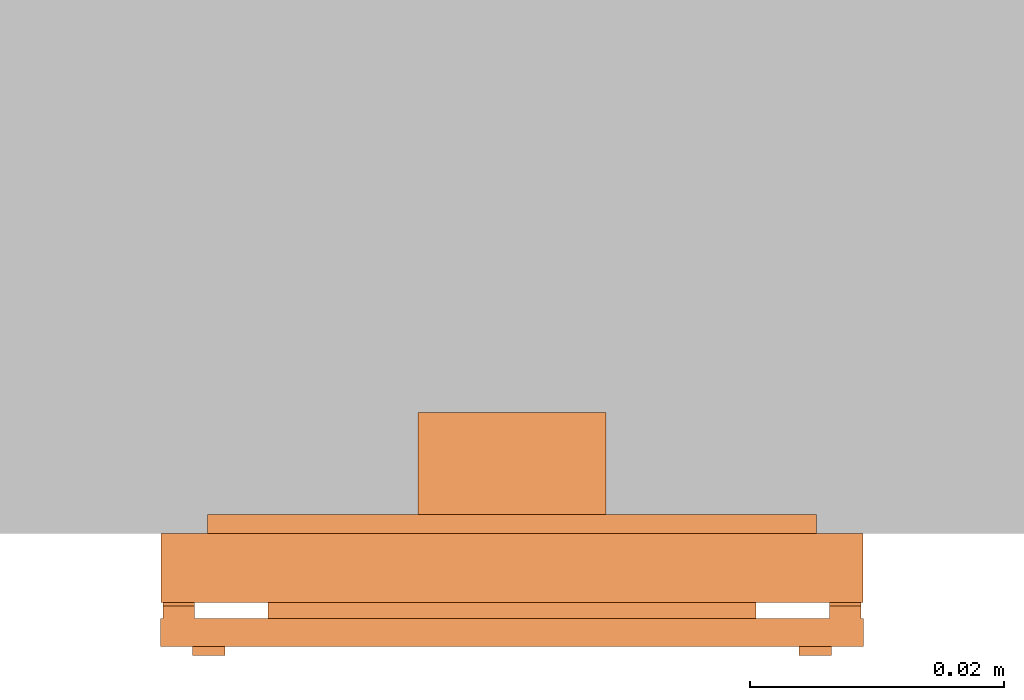
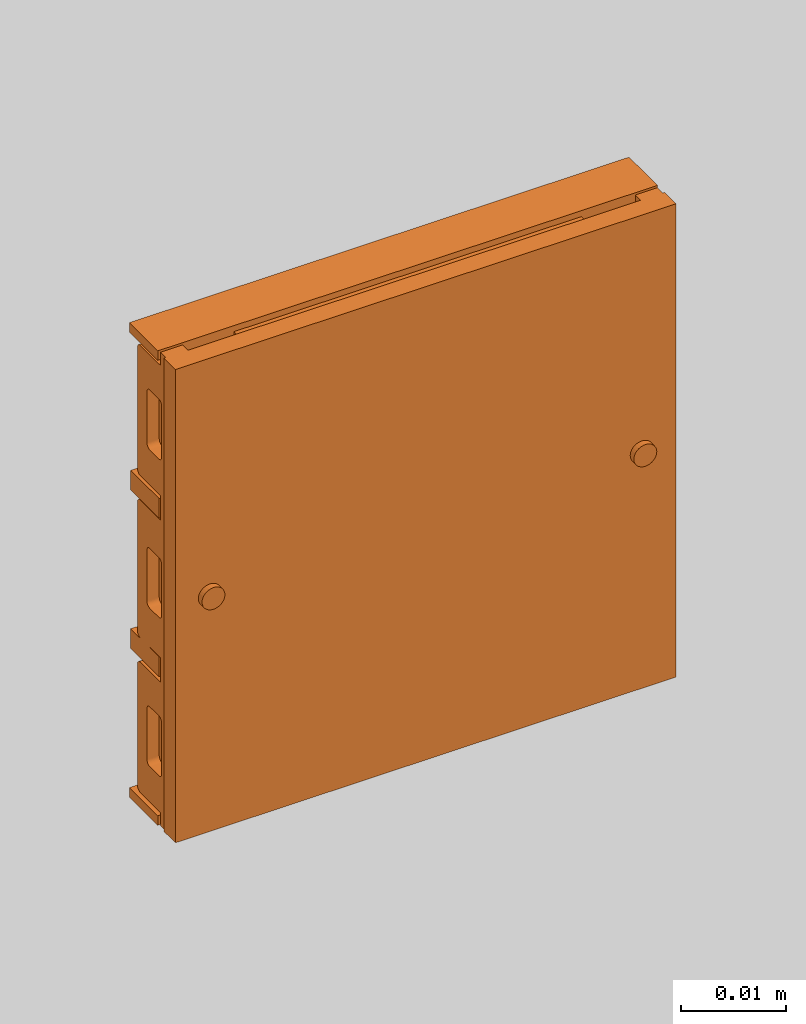
# One storey, part 2 of 2: 1 proxy.
"""IFC2X3 building model written with IfcOpenShell, lengths in metres."""

import ifcopenshell
import ifcopenshell.guid

model = None  # the IFC model being written
_history = None  # IfcOwnerHistory: only IFC2X3 demands one
_inside = {}  # id of a spatial element -> (the spatial element, [elements in it])
_under = {}  # id of a project, library or spatial element -> (it, [spatial elements below it])
_declared = {}  # id of a project -> (the project, [libraries it declares])
_typed = {}  # id of a type object -> (the type object, [elements of that type])
_made_of = {}  # id of a material, layer set ... -> (it, [elements and type objects made of it])


def new_model(schema):
    """Start an empty IFC model of exactly this schema.

    Asked for "IFC4X3", IfcOpenShell would pick the latest addendum, in which some entities
    have other attributes; the version numbers below select the first issue.
    IFC2X3 requires an IfcOwnerHistory on every rooted entity: one is made here for all.
    """
    global model, _history
    if schema == "IFC4X3":
        model = ifcopenshell.file(schema_version=(4, 3, 0, 0))
    else:
        model = ifcopenshell.file(schema=schema)
    _inside.clear()
    _under.clear()
    _declared.clear()
    _typed.clear()
    _made_of.clear()
    _history = None
    if model.schema == "IFC2X3":
        org = make("IfcOrganization", Name="unknown")
        user = make(
            "IfcPersonAndOrganization",
            ThePerson=make("IfcPerson", FamilyName="unknown"),
            TheOrganization=org,
        )
        app = make(
            "IfcApplication",
            ApplicationDeveloper=org,
            Version="unknown",
            ApplicationFullName="unknown",
            ApplicationIdentifier="unknown",
        )
        _history = make(
            "IfcOwnerHistory",
            OwningUser=user,
            OwningApplication=app,
            ChangeAction="ADDED",
            CreationDate=0,
        )
    return model


def make(cls, **values):
    """One entity of the class cls with the attributes given. An attribute that is None is left unset."""
    return model.create_entity(
        cls, **{name: value for name, value in values.items() if value is not None}
    )


def entity(cls, *values):
    """Any entity or typed value of the class cls, its attributes in the order of the schema. None: left unset."""
    e = model.create_entity(cls)
    for i, value in enumerate(values):
        if value is not None:
            e[i] = value
    return e


def rooted(cls, **values):
    """An entity with a GlobalId (a new one), such as an element, a storey or a relation."""
    return make(cls, GlobalId=ifcopenshell.guid.new(), OwnerHistory=_history, **values)


def si_unit(unit_type, name, prefix=None):
    """IfcSIUnit, for example si_unit("LENGTHUNIT", "METRE", prefix="MILLI")."""
    return make("IfcSIUnit", UnitType=unit_type, Prefix=prefix, Name=name)


def converted_unit(unit_type, name, factor, base, dimensions=None, offset=None):
    """IfcConversionBasedUnit, such as the inch: factor (a typed value) times the base unit."""
    return make(
        "IfcConversionBasedUnit"
        if offset is None
        else "IfcConversionBasedUnitWithOffset",
        ConversionOffset=offset,
        Dimensions=None
        if dimensions is None
        else entity("IfcDimensionalExponents", *dimensions),
        UnitType=unit_type,
        Name=name,
        ConversionFactor=make(
            "IfcMeasureWithUnit", ValueComponent=factor, UnitComponent=base
        ),
    )


def derived_unit(unit_type, elements):
    """IfcDerivedUnit: a product of units, each with its exponent."""
    return make(
        "IfcDerivedUnit",
        Elements=[
            make("IfcDerivedUnitElement", Unit=unit, Exponent=power)
            for unit, power in elements
        ],
        UnitType=unit_type,
    )


def assignment(units):
    """IfcUnitAssignment: the units of a project."""
    return None if units is None else make("IfcUnitAssignment", Units=units)


def point(xyz):
    """IfcCartesianPoint."""
    return None if xyz is None else make("IfcCartesianPoint", Coordinates=xyz)


def direction(xyz):
    """IfcDirection."""
    return None if xyz is None else make("IfcDirection", DirectionRatios=xyz)


def frame(location, z_axis=None, x_axis=None):
    """IfcAxis2Placement3D, a coordinate frame: its origin and axes. An axis left out is left unset."""
    return make(
        "IfcAxis2Placement3D",
        Location=point(location),
        Axis=direction(z_axis),
        RefDirection=direction(x_axis),
    )


def frame_2d(location, x_axis=None):
    """IfcAxis2Placement2D, a coordinate frame in the plane: its origin and x axis."""
    return make(
        "IfcAxis2Placement2D", Location=point(location), RefDirection=direction(x_axis)
    )


def origin():
    """The frame at (0, 0, 0) with its axes left unset."""
    return frame((0.0, 0.0, 0.0))


def origin_2d_with_axis():
    """The frame at (0, 0) in the plane with the x axis (1, 0) written out."""
    return frame_2d((0.0, 0.0), x_axis=(1.0, 0.0))


def place(relative_to, where):
    """IfcLocalPlacement: puts the frame where relative to a parent placement (None: the world)."""
    return make(
        "IfcLocalPlacement", PlacementRelTo=relative_to, RelativePlacement=where
    )


def context(
    kind, dimensions, precision=None, world=None, true_north=None, identifier=None
):
    """IfcGeometricRepresentationContext, for example the 3D "Model" context."""
    return make(
        "IfcGeometricRepresentationContext",
        ContextIdentifier=identifier,
        ContextType=kind,
        CoordinateSpaceDimension=dimensions,
        Precision=precision,
        WorldCoordinateSystem=world,
        TrueNorth=true_north,
    )


def subcontext(parent, identifier, kind, view, scale=None):
    """IfcGeometricRepresentationSubContext, for example "Body" below "Model"."""
    return make(
        "IfcGeometricRepresentationSubContext",
        ContextIdentifier=identifier,
        ContextType=kind,
        ParentContext=parent,
        TargetScale=scale,
        TargetView=view,
    )


def project(units=None, contexts=None):
    """IfcProject with its units and contexts."""
    return rooted(
        "IfcProject",
        Name="project",
        RepresentationContexts=contexts,
        UnitsInContext=assignment(units),
    )


def spatial(cls, under=None, at=None, **own):
    """A site, building, storey or space (cls), placed at a placement, below another one or the project."""
    s = rooted(cls, ObjectPlacement=at, **own)
    if under is not None:
        _under.setdefault(under.id(), (under, []))[1].append(s)
    return s


def polyline(points):
    """IfcPolyline through the points."""
    return make("IfcPolyline", Points=[point(p) for p in points])


def circle_curve(where, radius):
    """IfcCircle in the frame where."""
    return make("IfcCircle", Position=where, Radius=radius)


def parameter(value):
    """IfcParameterValue: where a trimmed curve begins or ends, as a parameter of its basis curve."""
    return model.create_entity("IfcParameterValue", value)


def trimmed(basis, trim1, trim2, sense, master):
    """IfcTrimmedCurve: the piece of a basis curve between two trims."""
    return make(
        "IfcTrimmedCurve",
        BasisCurve=basis,
        Trim1=trim1,
        Trim2=trim2,
        SenseAgreement=sense,
        MasterRepresentation=master,
    )


def segment(curve, same_sense, transition):
    """IfcCompositeCurveSegment."""
    return make(
        "IfcCompositeCurveSegment",
        Transition=transition,
        SameSense=same_sense,
        ParentCurve=curve,
    )


def composite_curve(segments, self_intersect=None):
    """IfcCompositeCurve: segments joined end to end."""
    return make("IfcCompositeCurve", Segments=segments, SelfIntersect=self_intersect)


def profile(cls, at=None, kind="AREA", **sizes):
    """A parametric profile (cls). Its sizes go by their IFC names, for example OverallWidth=200.0."""
    return make(cls, ProfileType=kind, Position=at, **sizes)


def rectangle(**sizes):
    """IfcRectangleProfileDef."""
    return profile("IfcRectangleProfileDef", **sizes)


def circle(**sizes):
    """IfcCircleProfileDef."""
    return profile("IfcCircleProfileDef", **sizes)


def outline(outer, holes=None, kind="AREA"):
    """IfcArbitraryClosedProfileDef: a profile drawn as a closed curve; with holes, ...WithVoids."""
    if holes is None:
        return make("IfcArbitraryClosedProfileDef", ProfileType=kind, OuterCurve=outer)
    return make(
        "IfcArbitraryProfileDefWithVoids",
        ProfileType=kind,
        OuterCurve=outer,
        InnerCurves=holes,
    )


def extrude(swept, where, along, depth):
    """IfcExtrudedAreaSolid: the profile swept, set in the frame where, extruded along a direction by depth."""
    return make(
        "IfcExtrudedAreaSolid",
        SweptArea=swept,
        Position=where,
        ExtrudedDirection=direction(along),
        Depth=depth,
    )


def shape(context_of_items, identifier, shape_type, items):
    """IfcShapeRepresentation: the items that make up one representation, for example the "Body"."""
    return make(
        "IfcShapeRepresentation",
        ContextOfItems=context_of_items,
        RepresentationIdentifier=identifier,
        RepresentationType=shape_type,
        Items=items,
    )


def source(mapping_origin, context_of_items, identifier, shape_type, items):
    """IfcRepresentationMap: a shape defined once, which mapped items show again and again."""
    return make(
        "IfcRepresentationMap",
        MappingOrigin=mapping_origin,
        MappedRepresentation=shape(context_of_items, identifier, shape_type, items),
    )


def transform(
    local_origin,
    x_axis=None,
    y_axis=None,
    z_axis=None,
    scale=None,
    scale2=None,
    scale3=None,
    uniform=True,
):
    """IfcCartesianTransformationOperator3D, or its non-uniform kind. x_axis, y_axis, z_axis: its Axis1, 2, 3."""
    if uniform:
        return make(
            "IfcCartesianTransformationOperator3D",
            Axis1=direction(x_axis),
            Axis2=direction(y_axis),
            LocalOrigin=point(local_origin),
            Scale=scale,
            Axis3=direction(z_axis),
        )
    return make(
        "IfcCartesianTransformationOperator3DnonUniform",
        Axis1=direction(x_axis),
        Axis2=direction(y_axis),
        LocalOrigin=point(local_origin),
        Scale=scale,
        Axis3=direction(z_axis),
        Scale2=scale2,
        Scale3=scale3,
    )


def mapped(mapping_source, mapping_target):
    """IfcMappedItem: shows the shape of a source again, moved by a transform."""
    return make(
        "IfcMappedItem", MappingSource=mapping_source, MappingTarget=mapping_target
    )


def made_of(thing, what):
    """Note that an element or type object is made of a material, layer set ...; save() writes the relation."""
    if what is not None:
        _made_of.setdefault(what.id(), (what, []))[1].append(thing)
    return thing


def type_object(cls, material=None, **own):
    """A type object (cls), such as IfcWallType, which elements share."""
    return made_of(rooted(cls, **own), material)


def type_shapes(of_type, sources):
    """Give a type object the sources (RepresentationMaps) that its elements show as mapped items."""
    of_type.RepresentationMaps = sources


def element(
    cls,
    number,
    at=None,
    inside=None,
    cuts=None,
    type_object=None,
    material=None,
    context=None,
    identifier="Body",
    shape_type=None,
    held_by="IfcProductDefinitionShape",
    body=None,
    shapes=None,
    **own,
):
    """One element of the class cls, such as IfcWall. Its Tag is "e" and its number.

    at: its placement. inside: the storey or other place that contains it. cuts: it is an
    opening in that element (IfcRelVoidsElement). A single representation is given by context,
    identifier, shape_type and body (its items); several are given by shapes. held_by: the class
    of the entity that holds the representations. save() writes the other relations.
    """
    e = rooted(cls, Tag="e%d" % number, ObjectPlacement=at, **own)
    if body is not None:
        shapes = [shape(context, identifier, shape_type, body)]
    if shapes is not None:
        e.Representation = make(held_by, Representations=shapes)
    if inside is not None:
        _inside.setdefault(inside.id(), (inside, []))[1].append(e)
    if cuts is not None:
        rooted(
            "IfcRelVoidsElement", RelatingBuildingElement=cuts, RelatedOpeningElement=e
        )
    if type_object is not None:
        _typed.setdefault(type_object.id(), (type_object, []))[1].append(e)
    return made_of(e, material)


def aggregate(whole, parts):
    """IfcRelAggregates: a whole, such as a stair, and the parts it consists of."""
    return rooted("IfcRelAggregates", RelatingObject=whole, RelatedObjects=parts)


def save(model, path):
    """Write the relations noted so far, then the file.

    IfcRelAggregates (storeys below a building ...), IfcRelContainedInSpatialStructure (elements
    in a storey), IfcRelDefinesByType, IfcRelAssociatesMaterial and IfcRelDeclares: one each for
    every whole, place, type object, material and project.
    """
    for whole, parts in _under.values():
        aggregate(whole, parts)
    for where, things in _inside.values():
        rooted(
            "IfcRelContainedInSpatialStructure",
            RelatedElements=things,
            RelatingStructure=where,
        )
    for kind, things in _typed.values():
        rooted("IfcRelDefinesByType", RelatedObjects=things, RelatingType=kind)
    for what, things in _made_of.values():
        rooted("IfcRelAssociatesMaterial", RelatedObjects=things, RelatingMaterial=what)
    for by, libraries in _declared.values():
        rooted("IfcRelDeclares", RelatingContext=by, RelatedDefinitions=libraries)
    model.write(path)


model = new_model("IFC2X3")

# Units and contexts
model_context = context("Model", 3, precision=1e-05, world=origin(), true_north=direction((6.12303176911189e-17, 1.0)))
body_context = subcontext(model_context, "Body", "Model", "MODEL_VIEW")
ifc_project = project(units=[si_unit("LENGTHUNIT", "METRE"), si_unit("AREAUNIT", "SQUARE_METRE"), si_unit("VOLUMEUNIT", "CUBIC_METRE"), converted_unit("PLANEANGLEUNIT", "DEGREE", entity("IfcRatioMeasure", 0.0174532925199433), si_unit("PLANEANGLEUNIT", "RADIAN"), dimensions=[0, 0, 0, 0, 0, 0, 0]), si_unit("MASSUNIT", "GRAM", prefix="KILO"), si_unit("TIMEUNIT", "SECOND"), si_unit("FREQUENCYUNIT", "HERTZ"), si_unit("THERMODYNAMICTEMPERATUREUNIT", "DEGREE_CELSIUS"), derived_unit("THERMALTRANSMITTANCEUNIT", [(si_unit("MASSUNIT", "GRAM", prefix="KILO"), 1), (si_unit("THERMODYNAMICTEMPERATUREUNIT", "KELVIN"), -1), (si_unit("TIMEUNIT", "SECOND"), -3)]), derived_unit("VOLUMETRICFLOWRATEUNIT", [(si_unit("LENGTHUNIT", "METRE"), 3), (si_unit("TIMEUNIT", "SECOND"), -1)]), si_unit("ELECTRICCURRENTUNIT", "AMPERE"), si_unit("ELECTRICVOLTAGEUNIT", "VOLT"), si_unit("POWERUNIT", "WATT"), si_unit("FORCEUNIT", "NEWTON", prefix="KILO"), si_unit("ILLUMINANCEUNIT", "LUX"), si_unit("LUMINOUSFLUXUNIT", "LUMEN"), si_unit("LUMINOUSINTENSITYUNIT", "CANDELA"), derived_unit("USERDEFINED", [(si_unit("MASSUNIT", "GRAM", prefix="KILO"), -1), (si_unit("LENGTHUNIT", "METRE"), -2), (si_unit("TIMEUNIT", "SECOND"), 3), (si_unit("LUMINOUSFLUXUNIT", "LUMEN"), 1)]), derived_unit("LINEARVELOCITYUNIT", [(si_unit("LENGTHUNIT", "METRE"), 1), (si_unit("TIMEUNIT", "SECOND"), -1)]), si_unit("PRESSUREUNIT", "PASCAL"), derived_unit("USERDEFINED", [(si_unit("LENGTHUNIT", "METRE"), -2), (si_unit("MASSUNIT", "GRAM", prefix="KILO"), 1), (si_unit("TIMEUNIT", "SECOND"), -2)])], contexts=[model_context])

# Site, building, storey
site_placement = place(None, origin())
site = spatial("IfcSite", under=ifc_project, at=site_placement, CompositionType="ELEMENT")
building_placement = place(site_placement, origin())
building = spatial("IfcBuilding", under=site, at=building_placement, CompositionType="ELEMENT")
storey_placement = place(building_placement, origin())
storey = spatial("IfcBuildingStorey", under=building, at=storey_placement, Name="Ebene 0", CompositionType="ELEMENT", Elevation=0.0)

# Proxy
building_element_proxy_type = type_object("IfcBuildingElementProxyType", PredefinedType="NOTDEFINED")
shared_shape = source(origin(), body_context, "Body", "SweptSolid", [
    extrude(circle(Radius=0.00126885775404484, at=frame_2d((0.0, -2.04989626027389e-18), x_axis=(1.0, 0.0))), frame((0.0238500000000189, 0.0, 0.0067025753045117)), (0.0, 0.0, 1.0), 0.00289742471932868),
    extrude(circle(Radius=0.00126885775404485, at=frame_2d((0.0, -2.04989626027389e-18), x_axis=(1.0, 0.0))), frame((-0.0238499999999811, 0.0, 0.0067025753045117)), (0.0, 0.0, 1.0), 0.00289742471932868),
    extrude(rectangle(XDim=0.0383999999999751, YDim=0.0539999999999661, at=origin_2d_with_axis()), frame((0.0, 0.0, 0.00543999999999828)), (0.0, 0.0, 1.0), 0.00255999999999986),
    extrude(rectangle(XDim=0.0552703139104043, YDim=0.0552999999999999, at=frame_2d((-4.16333634234434e-17, 0.0), x_axis=(1.0, 0.0))), frame((0.0, 0.0, 0.0067025753045117), z_axis=(0.0, 0.0, 1.0), x_axis=(0.0, -1.0, 0.0)), (0.0, 0.0, 1.0), 0.00219742471932881),
    extrude(outline(composite_curve([segment(trimmed(circle_curve(frame_2d((0.00932737944135405, 0.0067946551696999), x_axis=(-0.707106781186366, -0.70710678118673)), 0.000500000000000001), [parameter(359.999999999971)], [parameter(90.0000000000001)], True, "PARAMETER"), True, "CONTINUOUS"), segment(polyline([(0.00968093283194723, 0.0064411017791069), (0.0197218491247936, 0.0164820180719585)]), True, "CONTINUOUS"), segment(trimmed(circle_curve(frame_2d((0.0193682957342004, 0.0168355714625515), x_axis=(-0.707106781186366, -0.70710678118673)), 0.000500000000000005), [parameter(90.0000000000001)], [parameter(180.000000000029)], True, "PARAMETER"), True, "CONTINUOUS"), segment(polyline([(0.0197218491247934, 0.017189124853145), (0.0169641326781652, 0.0199468412997718)]), True, "CONTINUOUS"), segment(polyline([(0.0169641326781652, 0.0199468412997718), (0.0180601481890039, 0.0210428568106111)]), True, "CONTINUOUS"), segment(polyline([(0.0180601481890039, 0.0210428568106111), (0.0168475965250425, 0.0222344280121718)]), True, "CONTINUOUS"), segment(polyline([(0.0168475965250425, 0.0222344280121718), (-0.0222344280121631, -0.0168475965250539)]), True, "CONTINUOUS"), segment(polyline([(-0.0222344280121631, -0.0168475965250539), (-0.0210428568106018, -0.0180601481890147)]), True, "CONTINUOUS"), segment(polyline([(-0.0210428568106018, -0.0180601481890147), (-0.0199468412997631, -0.0169641326781755)]), True, "CONTINUOUS"), segment(polyline([(-0.0199468412997631, -0.0169641326781755), (-0.0171891248531349, -0.0197218491248023)]), True, "CONTINUOUS"), segment(trimmed(circle_curve(frame_2d((-0.0168355714625415, -0.0193682957342091), x_axis=(-0.707106781186366, -0.70710678118673)), 0.000500000000000001), [parameter(359.999999999971)], [parameter(90.0000000000005)], True, "PARAMETER"), True, "CONTINUOUS"), segment(polyline([(-0.0164820180719483, -0.0197218491248021), (-0.00644110177910191, -0.00968093283195054)]), True, "CONTINUOUS"), segment(trimmed(circle_curve(frame_2d((-0.00679465516969509, -0.00932737944135754), x_axis=(-0.707106781186366, -0.70710678118673)), 0.000500000000000001), [parameter(90.0000000000001)], [parameter(180.000000000029)], True, "PARAMETER"), True, "CONTINUOUS"), segment(polyline([(-0.00644110177910209, -0.00897382605076399), (-0.00919881822573034, -0.00621610960413717)]), True, "CONTINUOUS"), segment(polyline([(-0.00919881822573034, -0.00621610960413717), (-0.0071835638993492, -0.00420085527775499)]), True, "CONTINUOUS"), segment(polyline([(-0.0071835638993492, -0.00420085527775499), (-0.00442584745272095, -0.00695857172438182)]), True, "CONTINUOUS"), segment(trimmed(circle_curve(frame_2d((-0.00407229406212759, -0.00660501833378863), x_axis=(0.707106781186366, 0.707106781186729)), 0.0005), [parameter(179.999999999971)], [parameter(270.0)], True, "PARAMETER"), True, "CONTINUOUS"), segment(polyline([(-0.0037187406715344, -0.00695857172438163), (0.00695857172437972, 0.00371874067153799)]), True, "CONTINUOUS"), segment(trimmed(circle_curve(frame_2d((0.00660501833378654, 0.00407229406213099), x_axis=(-0.707106781186366, -0.70710678118673)), 0.000499999999999998), [parameter(90.0000000000004)], [parameter(180.000000000029)], True, "PARAMETER"), True, "CONTINUOUS"), segment(polyline([(0.00695857172437954, 0.00442584745272453), (0.00420085527775129, 0.00718356389935136)]), True, "CONTINUOUS"), segment(polyline([(0.00420085527775129, 0.00718356389935136), (0.00621610960413244, 0.00919881822573354)]), True, "CONTINUOUS"), segment(polyline([(0.00621610960413244, 0.00919881822573354), (0.00897382605076068, 0.00644110177910671)]), True, "CONTINUOUS")], self_intersect=False), holes=[composite_curve([segment(trimmed(circle_curve(frame_2d((0.0139092870609045, 0.0164963045301164), x_axis=(-0.707106781186366, -0.70710678118673)), 0.000500000000000005), [parameter(179.999999999997)], [parameter(269.999999999999)], True, "PARAMETER"), False, "CONTINUOUS"), segment(polyline([(0.0142628404514977, 0.0168498579207097), (0.0155356326576338, 0.0155770657145742)]), True, "CONTINUOUS"), segment(trimmed(circle_curve(frame_2d((0.0151820792670406, 0.0152235123239809), x_axis=(-0.707106781186366, -0.70710678118673)), 0.000500000000000001), [parameter(89.9999999999996)], [parameter(179.999999999997)], True, "PARAMETER"), False, "CONTINUOUS"), segment(polyline([(0.015535632657634, 0.0148699589333877), (0.0112929919705158, 0.0106273182462673)]), True, "CONTINUOUS"), segment(trimmed(circle_curve(frame_2d((0.0109394385799225, 0.0109808716368605), x_axis=(-0.707106781186366, -0.70710678118673)), 0.000499999999999998), [parameter(2.4935548702674e-12)], [parameter(89.9999999999996)], True, "PARAMETER"), False, "CONTINUOUS"), segment(polyline([(0.0105858851893293, 0.0106273182462671), (0.00931309298319317, 0.0119001104524026)]), True, "CONTINUOUS"), segment(trimmed(circle_curve(frame_2d((0.00966664637378634, 0.012253663842996), x_axis=(-0.707106781186366, -0.70710678118673)), 0.000499999999999998), [parameter(269.999999999999)], [parameter(2.54444374517082e-12)], True, "PARAMETER"), False, "CONTINUOUS"), segment(polyline([(0.00931309298319299, 0.0126072172335891), (0.0135557336703112, 0.0168498579207095)]), True, "CONTINUOUS")], self_intersect=False), composite_curve([segment(polyline([(0.00118136499954996, 0.00376838246875521), (0.00245415720568607, 0.00249559026261975)]), True, "CONTINUOUS"), segment(trimmed(circle_curve(frame_2d((0.00210060381509307, 0.00214203687202621), x_axis=(0.707106781186366, 0.707106781186729)), 0.000499999999999999), [parameter(270.0)], [parameter(2.94646585690781e-11)], True, "PARAMETER"), False, "CONTINUOUS"), segment(polyline([(0.00245415720568626, 0.00178848348143321), (-0.00178848348143194, -0.00245415720568717)]), True, "CONTINUOUS"), segment(trimmed(circle_curve(frame_2d((-0.00214203687202512, -0.00210060381509417), x_axis=(0.707106781186366, 0.707106781186729)), 0.000499999999999999), [parameter(179.999999999971)], [parameter(270.0)], True, "PARAMETER"), False, "CONTINUOUS"), segment(polyline([(-0.00249559026261848, -0.00245415720568736), (-0.0037683824687546, -0.0011813649995519)]), True, "CONTINUOUS"), segment(trimmed(circle_curve(frame_2d((-0.00341482907816123, -0.000827811608958716), x_axis=(0.707106781186366, 0.707106781186729)), 0.0005), [parameter(90.0000000000001)], [parameter(179.999999999971)], True, "PARAMETER"), False, "CONTINUOUS"), segment(polyline([(-0.00376838246875478, -0.000474258218365354), (0.000474258218363418, 0.00376838246875502)]), True, "CONTINUOUS"), segment(trimmed(circle_curve(frame_2d((0.000827811608956963, 0.00341482907816166), x_axis=(-0.707106781186366, -0.70710678118673)), 0.000500000000000001), [parameter(180.000000000029)], [parameter(270.0)], True, "PARAMETER"), False, "CONTINUOUS")], self_intersect=False), composite_curve([segment(trimmed(circle_curve(frame_2d((-0.0109808716368547, -0.0109394385799283), x_axis=(0.707106781186366, 0.707106781186729)), 0.000500000000000001), [parameter(270.0)], [parameter(2.94646585690781e-11)], True, "PARAMETER"), False, "CONTINUOUS"), segment(polyline([(-0.0106273182462615, -0.0112929919705213), (-0.0148699589333797, -0.0155356326576417)]), True, "CONTINUOUS"), segment(trimmed(circle_curve(frame_2d((-0.0152235123239729, -0.0151820792670487), x_axis=(0.707106781186366, 0.707106781186729)), 0.000500000000000001), [parameter(179.999999999971)], [parameter(270.0)], True, "PARAMETER"), False, "CONTINUOUS"), segment(polyline([(-0.0155770657145662, -0.0155356326576419), (-0.0168498579207024, -0.0142628404515064)]), True, "CONTINUOUS"), segment(trimmed(circle_curve(frame_2d((-0.016496304530109, -0.0139092870609132), x_axis=(0.707106781186366, 0.707106781186729)), 0.000500000000000005), [parameter(90.0000000000001)], [parameter(179.999999999971)], True, "PARAMETER"), False, "CONTINUOUS"), segment(polyline([(-0.0168498579207025, -0.0135557336703198), (-0.0126072172335844, -0.00931309298319947)]), True, "CONTINUOUS"), segment(trimmed(circle_curve(frame_2d((-0.0122536638429908, -0.00966664637379284), x_axis=(0.707106781186366, 0.707106781186729)), 0.000500000000000003), [parameter(2.94646585690781e-11)], [parameter(89.9999999999998)], True, "PARAMETER"), False, "CONTINUOUS"), segment(polyline([(-0.0119001104523978, -0.00931309298319929), (-0.0106273182462617, -0.0105858851893347)]), True, "CONTINUOUS")], self_intersect=False)]), frame((0.0250000000000063, 0.0, 0.00359090653120359), z_axis=(1.0, 0.0, 0.0), x_axis=(0.0, 0.707106781186366, -0.707106781186729)), (0.0, 0.0, 1.0), 0.00244999999998774),
    extrude(outline(composite_curve([segment(trimmed(circle_curve(frame_2d((0.0093273794413538, 0.00679465516970024), x_axis=(-0.707106781186339, -0.707106781186757)), 0.000500000000000001), [parameter(359.999999999967)], [parameter(89.9999999999996)], True, "PARAMETER"), True, "CONTINUOUS"), segment(polyline([(0.00968093283194698, 0.00644110177910727), (0.019721849124793, 0.0164820180719592)]), True, "CONTINUOUS"), segment(trimmed(circle_curve(frame_2d((0.0193682957341998, 0.0168355714625522), x_axis=(-0.707106781186339, -0.707106781186757)), 0.000500000000000005), [parameter(89.9999999999996)], [parameter(180.000000000031)], True, "PARAMETER"), True, "CONTINUOUS"), segment(polyline([(0.0197218491247928, 0.0171891248531458), (0.0169641326781644, 0.0199468412997725)]), True, "CONTINUOUS"), segment(polyline([(0.0169641326781644, 0.0199468412997725), (0.0180601481890031, 0.0210428568106118)]), True, "CONTINUOUS"), segment(polyline([(0.0180601481890031, 0.0210428568106118), (0.0168475965250416, 0.0222344280121724)]), True, "CONTINUOUS"), segment(polyline([(0.0168475965250416, 0.0222344280121724), (-0.0222344280121625, -0.0168475965250548)]), True, "CONTINUOUS"), segment(polyline([(-0.0222344280121625, -0.0168475965250548), (-0.0210428568106011, -0.0180601481890155)]), True, "CONTINUOUS"), segment(polyline([(-0.0210428568106011, -0.0180601481890155), (-0.0199468412997625, -0.0169641326781762)]), True, "CONTINUOUS"), segment(polyline([(-0.0199468412997625, -0.0169641326781762), (-0.0171891248531341, -0.0197218491248029)]), True, "CONTINUOUS"), segment(trimmed(circle_curve(frame_2d((-0.0168355714625407, -0.0193682957342098), x_axis=(-0.707106781186339, -0.707106781186757)), 0.000500000000000001), [parameter(359.999999999967)], [parameter(90.0000000000001)], True, "PARAMETER"), True, "CONTINUOUS"), segment(polyline([(-0.0164820180719475, -0.0197218491248027), (-0.00644110177910154, -0.00968093283195079)]), True, "CONTINUOUS"), segment(trimmed(circle_curve(frame_2d((-0.00679465516969472, -0.00932737944135782), x_axis=(-0.707106781186339, -0.707106781186757)), 0.000500000000000001), [parameter(89.9999999999996)], [parameter(180.000000000031)], True, "PARAMETER"), True, "CONTINUOUS"), segment(polyline([(-0.00644110177910175, -0.00897382605076424), (-0.0091988182257301, -0.00621610960413752)]), True, "CONTINUOUS"), segment(polyline([(-0.0091988182257301, -0.00621610960413752), (-0.00718356389934903, -0.00420085527775526)]), True, "CONTINUOUS"), segment(polyline([(-0.00718356389934903, -0.00420085527775526), (-0.00442584745272068, -0.00695857172438198)]), True, "CONTINUOUS"), segment(trimmed(circle_curve(frame_2d((-0.00407229406212732, -0.0066050183337888), x_axis=(0.707106781186338, 0.707106781186757)), 0.0005), [parameter(179.999999999968)], [parameter(270.0)], True, "PARAMETER"), True, "CONTINUOUS"), segment(polyline([(-0.00371874067153414, -0.00695857172438177), (0.00695857172437957, 0.00371874067153826)]), True, "CONTINUOUS"), segment(trimmed(circle_curve(frame_2d((0.0066050183337864, 0.00407229406213123), x_axis=(-0.707106781186339, -0.707106781186757)), 0.000499999999999998), [parameter(90.0000000000001)], [parameter(180.000000000032)], True, "PARAMETER"), True, "CONTINUOUS"), segment(polyline([(0.00695857172437937, 0.0044258474527248), (0.00420085527775101, 0.00718356389935152)]), True, "CONTINUOUS"), segment(polyline([(0.00420085527775101, 0.00718356389935152), (0.00621610960413208, 0.00919881822573378)]), True, "CONTINUOUS"), segment(polyline([(0.00621610960413208, 0.00919881822573378), (0.00897382605076043, 0.00644110177910706)]), True, "CONTINUOUS")], self_intersect=False), holes=[composite_curve([segment(trimmed(circle_curve(frame_2d((0.0139092870609039, 0.0164963045301169), x_axis=(-0.707106781186339, -0.707106781186757)), 0.000500000000000005), [parameter(180.0)], [parameter(270.0)], True, "PARAMETER"), False, "CONTINUOUS"), segment(polyline([(0.0142628404514971, 0.0168498579207103), (0.0155356326576332, 0.0155770657145748)]), True, "CONTINUOUS"), segment(trimmed(circle_curve(frame_2d((0.0151820792670401, 0.0152235123239815), x_axis=(-0.707106781186339, -0.707106781186757)), 0.000500000000000001), [parameter(90.0000000000001)], [parameter(180.0)], True, "PARAMETER"), False, "CONTINUOUS"), segment(polyline([(0.0155356326576335, 0.0148699589333883), (0.0112929919705154, 0.0106273182462678)]), True, "CONTINUOUS"), segment(trimmed(circle_curve(frame_2d((0.010939438579922, 0.0109808716368609), x_axis=(-0.707106781186339, -0.707106781186757)), 0.000499999999999998), [parameter(0.0)], [parameter(90.0000000000001)], True, "PARAMETER"), False, "CONTINUOUS"), segment(polyline([(0.0105858851893289, 0.0106273182462675), (0.00931309298319271, 0.011900110452403)]), True, "CONTINUOUS"), segment(trimmed(circle_curve(frame_2d((0.00966664637378588, 0.0122536638429963), x_axis=(-0.707106781186339, -0.707106781186757)), 0.000499999999999998), [parameter(270.0)], [parameter(0.0)], True, "PARAMETER"), False, "CONTINUOUS"), segment(polyline([(0.0093130929831925, 0.0126072172335895), (0.0135557336703105, 0.01684985792071)]), True, "CONTINUOUS")], self_intersect=False), composite_curve([segment(polyline([(0.00118136499954982, 0.00376838246875526), (0.00245415720568597, 0.00249559026261985)]), True, "CONTINUOUS"), segment(trimmed(circle_curve(frame_2d((0.002100603815093, 0.00214203687202628), x_axis=(0.707106781186338, 0.707106781186757)), 0.000499999999999999), [parameter(270.0)], [parameter(3.26706576879933e-11)], True, "PARAMETER"), False, "CONTINUOUS"), segment(polyline([(0.00245415720568618, 0.00178848348143331), (-0.00178848348143185, -0.00245415720568723)]), True, "CONTINUOUS"), segment(trimmed(circle_curve(frame_2d((-0.00214203687202503, -0.00210060381509427), x_axis=(0.707106781186338, 0.707106781186757)), 0.000499999999999999), [parameter(179.999999999969)], [parameter(270.000000000001)], True, "PARAMETER"), False, "CONTINUOUS"), segment(polyline([(-0.00249559026261839, -0.00245415720568745), (-0.00376838246875455, -0.00118136499955204)]), True, "CONTINUOUS"), segment(trimmed(circle_curve(frame_2d((-0.00341482907816118, -0.000827811608958862), x_axis=(0.707106781186338, 0.707106781186757)), 0.0005), [parameter(90.0000000000005)], [parameter(179.999999999968)], True, "PARAMETER"), False, "CONTINUOUS"), segment(polyline([(-0.00376838246875477, -0.000474258218365496), (0.00047425821836327, 0.00376838246875505)]), True, "CONTINUOUS"), segment(trimmed(circle_curve(frame_2d((0.000827811608956847, 0.00341482907816168), x_axis=(-0.707106781186339, -0.707106781186757)), 0.000500000000000001), [parameter(180.000000000032)], [parameter(270.0)], True, "PARAMETER"), False, "CONTINUOUS")], self_intersect=False), composite_curve([segment(trimmed(circle_curve(frame_2d((-0.0109808716368543, -0.0109394385799287), x_axis=(0.707106781186338, 0.707106781186757)), 0.000500000000000001), [parameter(270.0)], [parameter(3.26706576879933e-11)], True, "PARAMETER"), False, "CONTINUOUS"), segment(polyline([(-0.0106273182462611, -0.0112929919705217), (-0.0148699589333791, -0.0155356326576422)]), True, "CONTINUOUS"), segment(trimmed(circle_curve(frame_2d((-0.0152235123239723, -0.0151820792670493), x_axis=(0.707106781186338, 0.707106781186757)), 0.000500000000000001), [parameter(179.999999999969)], [parameter(270.0)], True, "PARAMETER"), False, "CONTINUOUS"), segment(polyline([(-0.0155770657145657, -0.0155356326576425), (-0.0168498579207018, -0.014262840451507)]), True, "CONTINUOUS"), segment(trimmed(circle_curve(frame_2d((-0.0164963045301084, -0.0139092870609139), x_axis=(0.707106781186338, 0.707106781186757)), 0.000500000000000005), [parameter(90.0000000000005)], [parameter(179.999999999968)], True, "PARAMETER"), False, "CONTINUOUS"), segment(polyline([(-0.016849857920702, -0.0135557336703205), (-0.012607217233584, -0.00931309298319995)]), True, "CONTINUOUS"), segment(trimmed(circle_curve(frame_2d((-0.0122536638429904, -0.00966664637379332), x_axis=(0.707106781186338, 0.707106781186757)), 0.000500000000000003), [parameter(3.27215465628967e-11)], [parameter(90.0000000000003)], True, "PARAMETER"), False, "CONTINUOUS"), segment(polyline([(-0.0119001104523974, -0.00931309298319974), (-0.0106273182462613, -0.0105858851893352)]), True, "CONTINUOUS")], self_intersect=False)]), frame((-0.0274499999999814, 0.0, 0.00359090653120412), z_axis=(1.0, 0.0, 0.0), x_axis=(0.0, 0.707106781186339, -0.707106781186757)), (0.0, 0.0, 1.0), 0.00244999999998774),
    extrude(outline(polyline([(-0.0276, -0.0277), (0.0276, -0.0277), (0.0276, -0.0266), (0.0261, -0.0266), (0.0261, -0.0104), (0.02745, -0.0104), (0.02745, -0.0081), (0.0261, -0.0081), (0.0261, 0.0081), (0.02745, 0.0081), (0.02745, 0.0104), (0.0261, 0.0104), (0.0261, 0.0266), (0.0276, 0.0266), (0.0276, 0.0277), (-0.0276, 0.0277), (-0.0276, 0.0266), (-0.0261, 0.0266), (-0.0261, 0.0104), (-0.02745, 0.0104), (-0.02745, 0.0081), (-0.0261, 0.0081), (-0.0261, -0.0081), (-0.02745, -0.0081), (-0.02745, -0.0104), (-0.0261, -0.0104), (-0.0261, -0.0266), (-0.0276, -0.0266), (-0.0276, -0.0277)])), origin(), (0.0, 0.0, 1.0), 0.00544000000000014),
    extrude(outline(composite_curve([segment(polyline([(-0.0191499999999997, -0.02395), (0.0191499999999997, -0.02395)]), True, "CONTINUOUS"), segment(trimmed(circle_curve(frame_2d((0.0191499999999997, -0.01915), x_axis=(1.0, 0.0)), 0.00479999999999996), [parameter(270.0)], [parameter(0.0)], True, "PARAMETER"), True, "CONTINUOUS"), segment(polyline([(0.0239499999999997, -0.01915), (0.0239499999999997, 0.01915)]), True, "CONTINUOUS"), segment(trimmed(circle_curve(frame_2d((0.0191499999999997, 0.01915), x_axis=(1.0, 0.0)), 0.0048), [parameter(5.08888749034163e-14)], [parameter(90.0000000000001)], True, "PARAMETER"), True, "CONTINUOUS"), segment(polyline([(0.0191499999999997, 0.02395), (-0.0191499999999997, 0.02395)]), True, "CONTINUOUS"), segment(trimmed(circle_curve(frame_2d((-0.0191499999999997, 0.01915), x_axis=(1.0, 0.0)), 0.0048), [parameter(90.0000000000001)], [parameter(180.0)], True, "PARAMETER"), True, "CONTINUOUS"), segment(polyline([(-0.0239499999999997, 0.01915), (-0.0239499999999997, -0.01915)]), True, "CONTINUOUS"), segment(trimmed(circle_curve(frame_2d((-0.0191499999999997, -0.01915), x_axis=(1.0, 0.0)), 0.00479999999999997), [parameter(180.0)], [parameter(270.0)], True, "PARAMETER"), True, "CONTINUOUS")], self_intersect=False)), frame((0.0, 0.0, -0.00150000000000173)), (0.0, 0.0, 1.0), 0.00199999999999986),
    extrude(circle(Radius=0.000499999999999999, at=origin_2d_with_axis()), frame((0.00508000000001882, -0.0200400000000254, -0.00847999980926727)), (0.0, 0.0, 1.0), 0.00697999980926554),
    extrude(circle(Radius=0.000500000000000001, at=origin_2d_with_axis()), frame((0.00254000000001872, -0.0174800000000254, -0.00847999980926727)), (0.0, 0.0, 1.0), 0.00697999980926554),
    extrude(circle(Radius=0.000499999999999998, at=origin_2d_with_axis()), frame((-0.00507999999998118, -0.0175000000000254, -0.00847999980926727)), (0.0, 0.0, 1.0), 0.00697999980926554),
    extrude(circle(Radius=0.000500000000000001, at=origin_2d_with_axis()), frame((-0.00253999999998128, -0.0174800000000254, -0.00847999980926727)), (0.0, 0.0, 1.0), 0.00697999980926554),
    extrude(circle(Radius=0.000500000000000001, at=origin_2d_with_axis()), frame((0.0, -0.0175000000000254, -0.00847999980926727)), (0.0, 0.0, 1.0), 0.00697999980926554),
    extrude(circle(Radius=0.000499999999999999, at=origin_2d_with_axis()), frame((0.00508000000001882, -0.0175000000000254, -0.00847999980926727)), (0.0, 0.0, 1.0), 0.00697999980926554),
    extrude(circle(Radius=0.000500000000000001, at=origin_2d_with_axis()), frame((0.00254000000001872, -0.0200200000000254, -0.00847999980926727)), (0.0, 0.0, 1.0), 0.00697999980926554),
    extrude(circle(Radius=0.000499999999999998, at=origin_2d_with_axis()), frame((0.0, -0.0200400000000254, -0.00847999980926727)), (0.0, 0.0, 1.0), 0.00697999980926554),
    extrude(circle(Radius=0.000500000000000001, at=origin_2d_with_axis()), frame((-0.00253999999998128, -0.0200200000000254, -0.00847999980926727)), (0.0, 0.0, 1.0), 0.00697999980926554),
    extrude(circle(Radius=0.000499999999999998, at=origin_2d_with_axis()), frame((-0.00507999999998118, -0.0200400000000254, -0.00847999980926727)), (0.0, 0.0, 1.0), 0.00697999980926554),
    extrude(outline(polyline([(-0.00740000000000001, -0.00285), (-0.00659999999999999, -0.00285), (-0.00659999999999999, 0.00245000000000002), (0.00660000000000001, 0.00245000000000002), (0.00660000000000001, -0.00285), (0.0074, -0.00285), (0.0074, 0.00324999999999998), (-0.00740000000000001, 0.00324999999999998), (-0.00740000000000001, -0.00285)])), frame((0.0, -0.0184500000000254, -0.00950000000000172)), (0.0, 0.0, 1.0), 0.008),
])
type_shapes(building_element_proxy_type, [shared_shape])
proxy_placement = place(storey_placement, frame((-4.44352968894139, -2.29307202699247, 1.20709910220295), z_axis=(0.0, -1.0, 0.0), x_axis=(1.0, 0.0, 0.0)))
element("IfcBuildingElementProxy", 1, at=proxy_placement, inside=storey, type_object=building_element_proxy_type, Name="SYS55_RF 1f", context=body_context, shape_type="MappedRepresentation", body=[
    mapped(shared_shape, transform((0.0, 0.0, 0.0), scale=1.0)),
])

save(model, "model.ifc")
